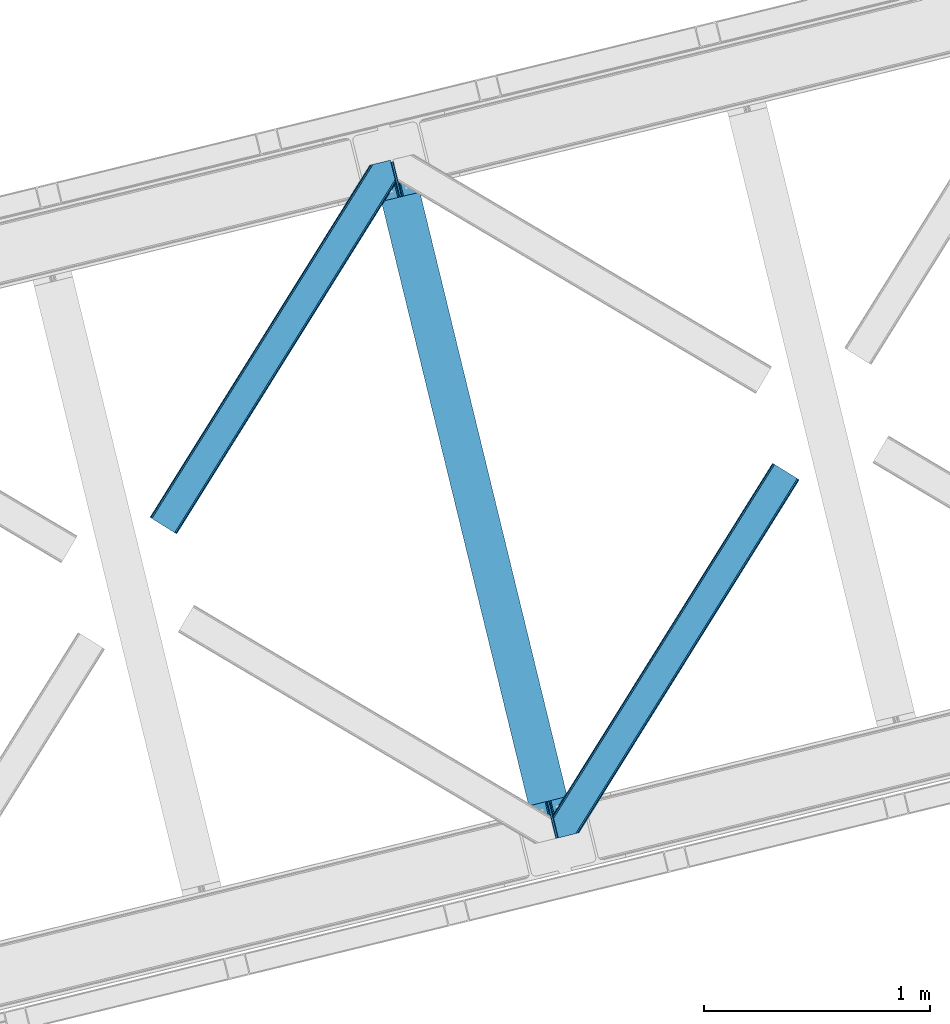
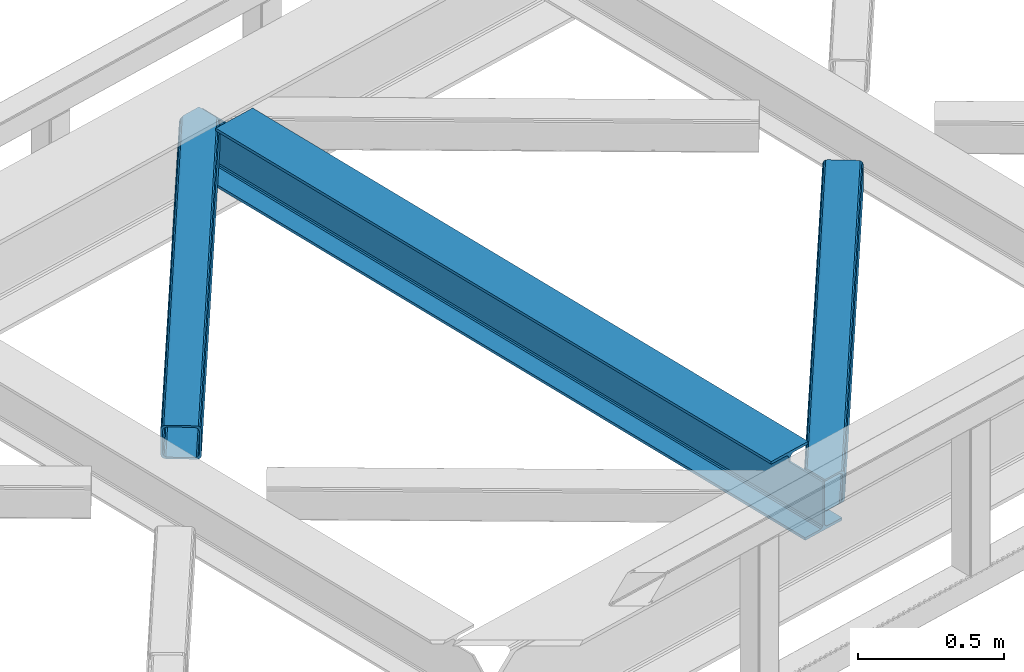
# One storey, part 59 of 93: 2 members, 1 beam.
"""IFC4 building model written with IfcOpenShell, lengths in millimetres."""

from ifc_helpers import new_model, entity, si_unit, converted_unit, derived_unit, direction, frame, origin, place, context, subcontext, project, spatial, triangles, polygons, material, type_object, element, save


model = new_model("IFC4")

# Units and contexts
model_context = context("Model", 3, precision=0.01, world=origin(), true_north=direction((6.12303176911189e-17, 1.0)))
plan_context = context("Plan", 3, precision=0.01, world=origin(), true_north=direction((6.12303176911189e-17, 1.0)))
body_context = subcontext(model_context, "Body", "Model", "MODEL_VIEW")
ifc_project = project(units=[si_unit("LENGTHUNIT", "METRE", prefix="MILLI"), si_unit("AREAUNIT", "SQUARE_METRE"), si_unit("VOLUMEUNIT", "CUBIC_METRE"), converted_unit("PLANEANGLEUNIT", "DEGREE", entity("IfcRatioMeasure", 0.0174532925199433), si_unit("PLANEANGLEUNIT", "RADIAN"), dimensions=[0, 0, 0, 0, 0, 0, 0]), si_unit("MASSUNIT", "GRAM", prefix="KILO"), derived_unit("MASSDENSITYUNIT", [(si_unit("MASSUNIT", "GRAM", prefix="KILO"), 1), (si_unit("LENGTHUNIT", "METRE"), -3)]), derived_unit("MOMENTOFINERTIAUNIT", [(si_unit("LENGTHUNIT", "METRE"), 4)]), si_unit("TIMEUNIT", "SECOND"), si_unit("FREQUENCYUNIT", "HERTZ"), si_unit("THERMODYNAMICTEMPERATUREUNIT", "DEGREE_CELSIUS"), derived_unit("THERMALTRANSMITTANCEUNIT", [(si_unit("MASSUNIT", "GRAM", prefix="KILO"), 1), (si_unit("THERMODYNAMICTEMPERATUREUNIT", "KELVIN"), -1), (si_unit("TIMEUNIT", "SECOND"), -3)]), derived_unit("VOLUMETRICFLOWRATEUNIT", [(si_unit("LENGTHUNIT", "METRE"), 3), (si_unit("TIMEUNIT", "SECOND"), -1)]), derived_unit("MASSFLOWRATEUNIT", [(si_unit("MASSUNIT", "GRAM", prefix="KILO"), 1), (si_unit("TIMEUNIT", "SECOND"), -1)]), derived_unit("ROTATIONALFREQUENCYUNIT", [(si_unit("TIMEUNIT", "SECOND"), -1)]), si_unit("ELECTRICCURRENTUNIT", "AMPERE"), si_unit("ELECTRICVOLTAGEUNIT", "VOLT"), si_unit("POWERUNIT", "WATT"), si_unit("FORCEUNIT", "NEWTON", prefix="KILO"), si_unit("ILLUMINANCEUNIT", "LUX"), si_unit("LUMINOUSFLUXUNIT", "LUMEN"), si_unit("LUMINOUSINTENSITYUNIT", "CANDELA"), derived_unit("USERDEFINED", [(si_unit("MASSUNIT", "GRAM", prefix="KILO"), -1), (si_unit("LENGTHUNIT", "METRE"), -2), (si_unit("TIMEUNIT", "SECOND"), 3), (si_unit("LUMINOUSFLUXUNIT", "LUMEN"), 1)]), derived_unit("LINEARVELOCITYUNIT", [(si_unit("LENGTHUNIT", "METRE"), 1), (si_unit("TIMEUNIT", "SECOND"), -1)]), si_unit("PRESSUREUNIT", "PASCAL"), derived_unit("USERDEFINED", [(si_unit("LENGTHUNIT", "METRE"), -2), (si_unit("MASSUNIT", "GRAM", prefix="KILO"), 1), (si_unit("TIMEUNIT", "SECOND"), -2)]), derived_unit("LINEARFORCEUNIT", [(si_unit("MASSUNIT", "GRAM", prefix="KILO"), 1), (si_unit("LENGTHUNIT", "METRE"), 1), (si_unit("TIMEUNIT", "SECOND"), -2), (si_unit("LENGTHUNIT", "METRE"), -1)]), derived_unit("PLANARFORCEUNIT", [(si_unit("MASSUNIT", "GRAM", prefix="KILO"), 1), (si_unit("LENGTHUNIT", "METRE"), 1), (si_unit("TIMEUNIT", "SECOND"), -2), (si_unit("LENGTHUNIT", "METRE"), -2)])], contexts=[model_context, plan_context])

# Site, building, storey
site_placement = place(None, origin())
site = spatial("IfcSite", under=ifc_project, at=site_placement, CompositionType="ELEMENT")
building_placement = place(site_placement, origin())
building = spatial("IfcBuilding", under=site, at=building_placement, CompositionType="ELEMENT")
storey_placement = place(building_placement, frame((0.0, 0.0, 15900.0)))
storey = spatial("IfcBuildingStorey", under=building, at=storey_placement, CompositionType="ELEMENT", Elevation=15900.0)

# Beam
ifc_material = material(Name="Metal painted (White)")
beam_type = type_object("IfcBeamType", PredefinedType="BEAM")
beam_placement = place(storey_placement, frame((-27174.2031424521, 11162.1857307485, 3441.0)))
element("IfcBeam", 1, at=beam_placement, inside=storey, type_object=beam_type, material=ifc_material, ObjectType="Steel Beam", PredefinedType="BEAM", context=body_context, shape_type="Tessellation", body=[
    polygons([(898.85391135252, 41.4445662733103, 11.000000000004), (898.85391135252, 41.4445662733103, 2.16573425859679e-12), (170.021610174761, 3031.3960252037, 2.16573425859679e-12), (170.021610174761, 3031.3960252037, 11.000000000004), (832.788371398898, 25.3403919499656, 11.000000000004), (103.956070221135, 3015.29185088035, 11.000000000004), (826.839621377606, 23.8903211957417, 12.2179274798217), (98.0073201998427, 3013.84178012613, 12.2179274798217), (821.796514621506, 22.6610105689216, 15.6862915010192), (92.9642134437384, 3012.61246949931, 15.6862915010192), (818.42681841833, 21.839611468714, 20.8770650821657), (89.5945172405625, 3011.7910703991, 20.8770650821657), (817.243538468644, 21.5511744621227, 27.0000000000047), (88.4112372908809, 3011.50263339251, 27.0000000000047), (81.6103728838888, 3009.84485074157, 27.0000000000047), (81.6103728838844, 3009.84485074157, 203.000000000006), (88.4112372908766, 3011.50263339251, 203.000000000006), (0.0, 2989.95145893039, 2.16573425859679e-12), (4.33146851719357e-12, 2989.95145893039, 10.9999999999997), (66.0655399536259, 3006.05563325373, 11.000000000004), (72.0142899749184, 3007.50570400796, 12.2179274798217), (77.0573967310183, 3008.73501463478, 15.6862915010192), (80.4270929342029, 3009.55641373498, 20.8770650821613), (817.243538468635, 21.5511744621206, 203.000000000006), (810.442674061647, 19.8933918111876, 203.000000000006), (810.442674061647, 19.8933918111876, 27.0000000000047), (809.259394111961, 19.6049548045963, 20.8770650821613), (805.889697908786, 18.7835557043887, 15.6862915010192), (800.846591152681, 17.5542450775685, 12.2179274798217), (794.897841131384, 16.1041743233425, 11.000000000004), (728.832301177763, 0.0, 10.9999999999997), (728.832301177763, 0.0, 2.16573425859679e-12), (777.543778045845, 184.415062601692, 203.069791966819), (125.888966506596, 2857.75452019162, 203.000000000006), (126.111847295746, 2856.84017775719, 203.617301946336), (126.12476154027, 2856.7871977843, 217.000003693143), (777.398574796916, 185.010597404072, 217.000003676718), (777.399445404814, 185.007025963192, 204.00000679514), (770.833476881403, 182.385463974445, 203.006342981529), (770.610629219866, 183.299815969774, 203.617301946336), (770.597714975338, 183.352795942669, 217.000003693143), (119.323901718691, 2855.1293963229, 217.000003676718), (119.323031110798, 2855.13296776378, 204.00000679514), (119.178731521743, 2855.72494066435, 203.076120467494), (119.088102099604, 2856.09673754069, 203.000000000006), (778.582059520952, 185.298194377514, 223.122939328039), (781.951055929623, 186.122464201393, 228.313710402595), (786.993691333646, 187.353708426697, 231.782072735464), (792.942270204354, 188.804481281379, 232.999999602236), (859.007721069873, 204.909021065315, 232.999999283132), (859.00624773344, 204.915065042188, 243.999994005812), (688.984866829523, 163.469558245298, 243.999994827032), (688.986340165961, 163.463514268424, 233.000000104353), (755.051791031484, 179.568054052358, 232.999999785253), (761.000696159814, 181.017488520584, 231.782072861012), (766.044260666937, 182.244921343716, 228.313710479427), (769.414647576681, 183.063487001148, 223.12293937232), (118.140416994656, 2854.84179934945, 223.122939328039), (114.771420585981, 2854.01752952557, 228.313710402595), (109.728785181961, 2852.78628530027, 231.782072735464), (103.780206311249, 2851.33551244559, 232.999999602236), (37.7147554457342, 2835.23097266165, 232.999999283128), (37.7162287821717, 2835.22492868478, 243.999994005812), (207.737609686088, 2876.67043548167, 243.999994827032), (207.736136349647, 2876.67647945854, 233.000000104357), (141.670685484123, 2860.57193967461, 232.999999785253), (135.721780355793, 2859.12250520639, 231.782072861012), (130.678215848667, 2857.89507238325, 228.313710479427), (127.307828938922, 2857.07650672582, 223.12293937232)], [[[1, 2, 3, 4]], [[5, 1, 4, 6]], [[7, 5, 6, 8]], [[9, 7, 8, 10]], [[11, 9, 10, 12]], [[13, 11, 12, 14]], [[15, 16, 17, 14, 12, 10, 8, 6, 4, 3, 18, 19, 20, 21, 22, 23]], [[13, 24, 25, 26, 27, 28, 29, 30, 31, 32, 2, 1, 5, 7, 9, 11]], [[2, 32, 18, 3]], [[32, 31, 19, 18]], [[31, 30, 20, 19]], [[27, 26, 15, 23]], [[28, 27, 23, 22]], [[29, 28, 22, 21]], [[30, 29, 21, 20]], [[33, 24, 13, 14, 17, 34, 35, 36, 37, 38]], [[25, 39, 40, 41, 42, 43, 44, 16, 15, 26]], [[39, 25, 24, 33]], [[45, 34, 17, 16]], [[41, 40, 38, 37, 46, 47, 48, 49, 50, 51, 52, 53, 54, 55, 56, 57]], [[42, 58, 59, 60, 61, 62, 63, 64, 65, 66, 67, 68, 69, 36, 35, 43]], [[46, 37, 36, 69]], [[47, 46, 69, 68]], [[48, 47, 68, 67]], [[49, 48, 67, 66]], [[50, 49, 66, 65]], [[51, 50, 65, 64]], [[52, 51, 64, 63]], [[53, 52, 63, 62]], [[54, 53, 62, 61]], [[55, 54, 61, 60]], [[56, 55, 60, 59]], [[57, 56, 59, 58]], [[41, 57, 58, 42]]], closed=False),
])

# Members
member_type_1 = type_object("IfcMemberType", PredefinedType="BRACE")
member_1_placement = place(storey_placement, frame((-28160.1625305176, 12527.4864990234, 3510.00011901855)))
element("IfcMember", 2, at=member_1_placement, inside=storey, type_object=member_type_1, ObjectType="Steel Horizontal Brace", PredefinedType="BRACE", context=body_context, shape_type="Tessellation", body=[
    triangles([(933.019793701173, 1535.69230957031, 0.0), (967.780462646486, 1393.09171142578, 0.0), (14.8479309082031, 64.8704589843746, 0.0), (103.9169128418, 9.2680389404286, 0.0), (928.803771972656, 1552.99125366211, 5.49966430664063), (928.943298339844, 1552.41687011719, 5.20782165527635), (930.803649902344, 1544.78710327148, 1.33247680664135), (971.998809814453, 1375.79276733398, 5.49966430664063), (971.856958007815, 1376.36715087891, 5.20782165527635), (969.998931884766, 1383.99691772461, 1.33247680664135), (972.210424804689, 1375.53813171387, 5.85313110351854), (972.424365234376, 1375.28349609375, 6.20659790039281), (928.915393066407, 1553.57028808594, 5.74383544921875), (972.726672363282, 1375.53813171387, 6.35310058594041), (929.029339599612, 1554.1772277832, 5.9996337890625), (973.026654052737, 1375.79276733398, 6.49960327148438), (929.145611572269, 1554.78416748047, 6.25659484863354), (929.254907226565, 1555.36203918457, 6.49960327148438), (4.34857177734375, 71.4223846435543, 5.12526855468968), (1.13248901367479, 73.4315643310547, 10.8028289794929), (973.361517333986, 1630.84347839355, 10.8028289794929), (976.917114257813, 1631.70970458984, 6.49960327148438), (9.16455688476708, 68.415591430663, 1.33247680664135), (971.508142089846, 1630.39118041992, 17.5000946044929), (0.0, 74.1373352050778, 17.5000946044929), (1081.10145263672, 1548.91708374023, 6.49960327148438), (1056.20762329102, 1651.03759460449, 6.49960327148438), (971.508142089846, 1630.39118041992, 122.500662231447), (0.0, 74.1373352050778, 122.500662231447), (973.361517333986, 1630.84347839355, 129.197927856447), (1.13248901367479, 73.4315643310547, 129.197927856447), (978.633288574219, 1632.12828369141, 134.874325561526), (4.34857177734375, 71.4223846435543, 134.874325561526), (986.530480957033, 1634.05374755859, 138.667117309571), (9.16455688476708, 68.415591430663, 138.667117309571), (995.841540527344, 1636.32221374512, 139.999594116212), (14.8479309082031, 64.8704589843746, 139.999594116212), (118.760192871094, 0.0, 17.5000946044929), (117.632354736328, 0.705770874023074, 10.8028289794929), (1085.14306640625, 1551.25066223144, 10.9783996582046), (1087.41734619141, 1552.56453552246, 13.5003387451179), (109.597961425781, 5.7205810546875, 1.33247680664135), (114.413946533205, 2.71495056152344, 5.12526855468968), (1087.57082519531, 1551.93550415039, 17.5000946044929), (1081.77815551758, 1575.70265808105, 139.999594116212), (1063.00953369141, 1652.69563293457, 139.999594116212), (103.9169128418, 9.2680389404286, 139.999594116212), (1083.99429931641, 1566.60670166016, 138.667117309571), (109.597961425781, 5.7205810546875, 138.667117309571), (1085.87325439453, 1558.89670715332, 134.874325561526), (114.413946533205, 2.71495056152344, 134.874325561526), (1087.12899169922, 1553.74469604492, 129.197927856447), (117.632354736328, 0.705770874023074, 129.197927856447), (1087.57082519531, 1551.93550415039, 122.500662231447), (118.760192871094, 0.0, 122.500662231447), (1082.53857421875, 1566.77413330078, 12.1260040283232), (1083.96639404297, 1566.72413635254, 13.5003387451179), (1077.8528137207, 1569.98556518555, 8.3320495605476), (1074.6483581543, 1577.50138549805, 6.99957275390625), (1056.69364013672, 1651.1561920166, 6.99957275390625), (1005.57350463867, 1638.69532470703, 6.99957275390625), (20.784777832032, 61.1625457763676, 6.99957275390625), (97.9777404785164, 12.9736267089847, 6.99957275390625), (108.474774169925, 6.42170104980505, 12.1260040283232), (111.693182373048, 4.41252136230469, 17.8035644531265), (1084.81285400391, 1563.2510925293, 17.8035644531265), (103.661114501956, 9.42849426269458, 8.3320495605476), (1085.25236206055, 1561.44190063477, 24.4996673583992), (112.823345947269, 3.70791320800708, 24.4996673583992), (983.093481445314, 1633.21542663574, 17.8035644531265), (981.240106201174, 1632.76429138184, 24.4996673583992), (7.0693359375, 69.7248138427731, 17.8035644531265), (5.94149780273438, 70.4305847167961, 24.4996673583992), (988.369903564453, 1634.50139465332, 12.1260040283232), (10.2877441406272, 67.7156341552727, 12.1260040283232), (996.262445068362, 1636.42569580078, 8.3320495605476), (15.1037292480469, 64.7100036621086, 8.3320495605476), (981.240106201174, 1632.76429138184, 115.501089477541), (5.94149780273438, 70.4305847167961, 115.501089477541), (996.262445068362, 1636.42569580078, 131.667544555665), (1005.57350463867, 1638.69532470703, 133.000021362306), (1063.00953369141, 1652.69563293457, 133.000021362306), (988.369903564453, 1634.50139465332, 127.87475280762), (983.093481445314, 1633.21542663574, 122.196029663086), (20.784777832032, 61.1625457763676, 133.000021362306), (15.1037292480469, 64.7100036621086, 131.667544555665), (10.2877441406272, 67.7156341552727, 127.87475280762), (7.0693359375, 69.7248138427731, 122.196029663086), (108.474774169925, 6.42170104980505, 127.87475280762), (111.693182373048, 4.41252136230469, 122.196029663086), (112.823345947269, 3.70791320800708, 115.501089477541), (97.9777404785164, 12.9736267089847, 133.000021362306), (103.661114501956, 9.42849426269458, 131.667544555665), (1085.25236206055, 1561.44190063477, 115.501089477541), (1084.81285400391, 1563.2510925293, 122.196029663086), (1083.55711669922, 1568.40310363769, 127.87475280762), (1081.67583618164, 1576.11309814453, 131.667544555665), (1079.45969238281, 1585.20905456543, 133.000021362306)], [[1, 2, 3], [4, 3, 2], [1, 5, 2], [6, 5, 1], [1, 7, 6], [2, 5, 8], [8, 9, 2], [10, 2, 9], [11, 8, 5], [12, 11, 13], [14, 12, 15], [16, 14, 17], [17, 18, 16], [15, 17, 14], [13, 15, 12], [5, 13, 11], [17, 19, 18], [19, 17, 15], [13, 19, 15], [19, 13, 5], [5, 6, 19], [20, 21, 18], [18, 19, 20], [21, 22, 18], [19, 6, 7], [7, 1, 23], [3, 23, 1], [7, 23, 19], [24, 21, 20], [20, 25, 24], [18, 26, 16], [26, 18, 22], [27, 26, 22], [28, 24, 29], [25, 29, 24], [30, 28, 31], [29, 31, 28], [32, 30, 33], [31, 33, 30], [34, 32, 35], [33, 35, 32], [36, 34, 37], [35, 37, 34], [38, 39, 40], [40, 41, 38], [42, 10, 9], [39, 12, 16], [16, 40, 39], [16, 26, 40], [9, 39, 43], [9, 12, 39], [9, 43, 42], [2, 10, 4], [42, 4, 10], [41, 44, 38], [45, 36, 37], [36, 45, 46], [37, 47, 45], [48, 45, 47], [47, 49, 48], [50, 48, 49], [49, 51, 50], [52, 50, 51], [51, 53, 52], [54, 52, 53], [53, 55, 54], [44, 54, 38], [55, 38, 54], [56, 40, 26], [41, 40, 56], [56, 57, 41], [58, 26, 59], [26, 58, 56], [60, 59, 26], [59, 61, 62], [61, 59, 60], [62, 63, 59], [64, 65, 66], [66, 57, 64], [58, 59, 63], [63, 67, 58], [56, 58, 67], [67, 64, 56], [57, 56, 64], [68, 66, 65], [65, 69, 68], [70, 71, 72], [73, 72, 71], [74, 70, 75], [72, 75, 70], [76, 74, 77], [75, 77, 74], [61, 76, 62], [77, 62, 76], [71, 78, 73], [79, 73, 78], [34, 36, 80], [46, 81, 36], [81, 46, 82], [81, 80, 36], [83, 34, 80], [83, 32, 34], [32, 84, 30], [84, 32, 83], [28, 84, 78], [84, 28, 30], [61, 22, 76], [70, 74, 22], [74, 76, 22], [61, 60, 22], [71, 70, 24], [21, 24, 70], [28, 71, 24], [71, 28, 78], [70, 22, 21], [80, 81, 85], [85, 86, 80], [83, 80, 86], [86, 87, 83], [84, 83, 87], [87, 88, 84], [78, 84, 88], [88, 79, 78], [53, 89, 90], [91, 38, 55], [53, 90, 55], [53, 51, 89], [90, 91, 55], [89, 51, 49], [92, 47, 37], [47, 93, 49], [93, 47, 92], [93, 89, 49], [39, 64, 43], [69, 38, 91], [38, 65, 39], [65, 38, 69], [39, 65, 64], [4, 63, 3], [42, 43, 64], [64, 67, 42], [67, 63, 4], [4, 42, 67], [87, 35, 33], [37, 85, 92], [37, 86, 85], [86, 37, 35], [87, 86, 35], [79, 29, 25], [31, 88, 87], [33, 31, 87], [88, 31, 29], [79, 88, 29], [23, 75, 19], [3, 63, 62], [62, 77, 3], [77, 75, 23], [23, 3, 77], [20, 19, 75], [25, 73, 79], [72, 25, 20], [25, 72, 73], [72, 20, 75], [66, 41, 57], [54, 44, 68], [44, 66, 68], [68, 94, 54], [44, 41, 66], [95, 54, 94], [52, 54, 95], [50, 95, 96], [95, 50, 52], [96, 48, 50], [97, 48, 96], [97, 98, 45], [97, 45, 48], [98, 46, 45], [98, 82, 46], [81, 98, 85], [81, 82, 98], [92, 85, 98], [95, 94, 90], [91, 90, 94], [96, 95, 89], [90, 89, 95], [97, 96, 93], [89, 93, 96], [98, 97, 92], [93, 92, 97], [94, 68, 91], [69, 91, 68]]),
])
member_type_2 = type_object("IfcMemberType", PredefinedType="BRACE")
member_2_placement = place(storey_placement, frame((-26379.092175293, 11184.3289489746, 3510.00011901855)))
element("IfcMember", 3, at=member_2_placement, inside=storey, type_object=member_type_2, ObjectType="Steel Horizontal Brace", PredefinedType="BRACE", context=body_context, shape_type="Tessellation", body=[
    triangles([(986.153759765624, 1647.42967529297, 0.0), (1075.22274169922, 1591.82725524902, 0.0), (119.788037109374, 259.603921508789, 0.0), (154.548706054688, 117.003323364259, 0.0), (115.902227783201, 275.544808959961, 4.52065429687718), (117.571893310545, 268.698715209961, 1.33247680664135), (158.434515380857, 101.062435913087, 4.52065429687718), (156.764849853513, 107.908529663086, 1.33247680664135), (114.825549316403, 275.742471313477, 5.52059326172093), (115.130181884764, 275.923855590821, 5.35316162109666), (158.132208251951, 99.1218566894531, 5.27525939941552), (115.439465332031, 276.107565307617, 5.18107910156323), (158.232202148436, 99.7776306152355, 5.02062377929906), (158.188018798828, 99.4822998046875, 5.13573303222802), (115.541784667967, 276.1680267334, 5.12526855468968), (115.683636474609, 275.921530151367, 4.88574829101708), (158.336846923827, 100.433404541016, 4.76482543945531), (158.032214355466, 98.4928253173839, 5.52059326172093), (1085.71977539062, 1585.27416687012, 5.12526855468968), (1080.90146484375, 1588.28096008301, 1.33247680664135), (1088.93818359375, 1583.26498718262, 10.8028289794929), (114.21163330078, 21.8533172607422, 10.8028289794929), (109.467736816405, 20.6964111328125, 5.52059326172093), (1090.06602172851, 1582.56037902832, 17.5000946044929), (116.062683105469, 22.3044525146488, 17.5000946044929), (6.75307617187354, 102.619317626953, 5.52059326172093), (31.3632019042961, 1.65803833007885, 5.52059326172093), (1090.06602172851, 1582.56037902832, 122.500662231447), (116.062683105469, 22.3044525146488, 122.500662231447), (1088.93818359375, 1583.26498718262, 129.197927856447), (114.21163330078, 21.8533172607422, 129.197927856447), (1085.71977539062, 1585.27416687012, 134.874325561526), (108.935211181641, 20.5673492431652, 134.874325561526), (1080.90146484375, 1588.28096008301, 138.667117309571), (101.042669677732, 18.6430480957042, 138.667117309571), (1075.22274169922, 1591.82725524902, 139.999594116212), (91.7292846679666, 16.3722564697273, 139.999594116212), (980.472711181639, 1650.97597045899, 1.33247680664135), (975.656726074216, 1653.98276367187, 5.12526855468968), (1.69059448242115, 100.411312866212, 10.9621215820334), (972.438317871092, 1655.99078063965, 10.8028289794929), (971.308154296872, 1656.69655151367, 17.5000946044929), (0.239520263668965, 99.7776306152355, 12.5201660156272), (0.0, 100.760128784181, 17.5000946044929), (5.79266967773219, 76.9941375732433, 139.999594116212), (986.153759765624, 1647.42967529297, 139.999594116212), (24.5612915039055, 0.0, 139.999594116212), (971.308154296872, 1656.69655151367, 122.500662231447), (0.0, 100.760128784181, 122.500662231447), (980.472711181639, 1650.97597045899, 138.667117309571), (3.57652587890334, 86.0889312744148, 138.667117309571), (975.656726074216, 1653.98276367187, 134.874325561526), (1.69524536132667, 93.7989257812496, 134.874325561526), (972.438317871092, 1655.99078063965, 129.197927856447), (0.43950805663917, 98.9509368896488, 129.197927856447), (29.9237548828096, 1.30689697265734, 6.99957275390625), (12.1969299316406, 74.0326904296871, 6.99957275390625), (8.99247436523365, 81.5485107421882, 8.3320495605476), (3.88580932616969, 84.8122650146488, 12.5201660156272), (1069.28589477539, 1595.53400573731, 6.99957275390625), (81.9949951171875, 14.0003082275398, 6.99957275390625), (992.090606689453, 1643.72292480469, 6.99957275390625), (981.593572998045, 1650.27601318359, 12.1260040283232), (978.375164794921, 1652.28403015137, 17.8035644531265), (2.75797119140407, 89.4445404052731, 17.8035644531265), (986.409558105468, 1647.2692199707, 8.3320495605476), (977.245001220701, 1652.98980102539, 24.4996673583992), (2.31613769531032, 91.2537322998051, 24.4996673583992), (977.245001220701, 1652.98980102539, 115.501089477541), (2.31613769531032, 91.2537322998051, 115.501089477541), (4.01370849609157, 84.2925292968757, 127.87475280762), (2.75797119140407, 89.4445404052731, 122.196029663086), (5.89266357421729, 76.5825347900391, 131.667544555665), (8.10880737304615, 67.4865783691403, 133.000021362306), (24.5612915039055, 0.0, 133.000021362306), (978.375164794921, 1652.28403015137, 122.196029663086), (981.593572998045, 1650.27601318359, 127.87475280762), (986.409558105468, 1647.2692199707, 131.667544555665), (992.090606689453, 1643.72292480469, 133.000021362306), (1069.28589477539, 1595.53400573731, 133.000021362306), (81.9949951171875, 14.0003082275398, 133.000021362306), (1079.78060302734, 1588.9809173584, 12.1260040283232), (1082.99901123047, 1586.97290039063, 17.8035644531265), (1084.12917480469, 1586.2671295166, 24.4996673583992), (1074.96461791992, 1591.98771057129, 8.3320495605476), (1079.78060302734, 1588.9809173584, 127.87475280762), (1084.12917480469, 1586.2671295166, 115.501089477541), (1082.99901123047, 1586.97290039063, 122.196029663086), (1074.96461791992, 1591.98771057129, 131.667544555665), (91.3083801269531, 16.2699371337894, 131.667544555665), (99.2032470703125, 18.1942382812504, 127.87475280762), (104.477343749997, 19.4802062988292, 122.196029663086), (106.330718994141, 19.9325042724613, 115.501089477541), (91.3083801269531, 16.2699371337894, 8.3320495605476), (104.477343749997, 19.4802062988292, 17.8035644531265), (99.2032470703125, 18.1942382812504, 12.1260040283232), (106.330718994141, 19.9325042724613, 24.4996673583992)], [[1, 2, 3], [4, 3, 2], [5, 3, 4], [3, 5, 6], [4, 7, 5], [7, 4, 8], [9, 10, 11], [10, 12, 13], [13, 14, 10], [12, 15, 16], [16, 17, 12], [16, 5, 7], [7, 17, 16], [17, 13, 12], [14, 11, 10], [11, 18, 9], [19, 14, 13], [13, 20, 19], [13, 17, 20], [17, 7, 20], [7, 8, 20], [21, 22, 18], [18, 19, 21], [14, 19, 11], [18, 11, 19], [22, 23, 18], [21, 24, 25], [25, 22, 21], [2, 20, 4], [8, 4, 20], [23, 26, 18], [23, 27, 26], [9, 18, 26], [24, 28, 29], [29, 25, 24], [28, 30, 29], [31, 29, 30], [30, 32, 31], [33, 31, 32], [32, 34, 33], [35, 33, 34], [34, 36, 35], [37, 35, 36], [38, 6, 5], [5, 39, 38], [5, 15, 39], [40, 41, 9], [41, 39, 15], [42, 41, 40], [40, 43, 42], [43, 44, 42], [9, 26, 40], [38, 1, 6], [3, 6, 1], [36, 45, 37], [36, 46, 45], [45, 47, 37], [48, 42, 44], [44, 49, 48], [46, 50, 51], [51, 45, 46], [50, 52, 53], [53, 51, 50], [52, 54, 55], [55, 53, 52], [54, 48, 49], [49, 55, 54], [27, 56, 57], [26, 57, 58], [57, 26, 27], [59, 40, 26], [26, 58, 59], [43, 40, 59], [60, 57, 61], [60, 62, 57], [57, 56, 61], [63, 64, 65], [65, 59, 63], [66, 63, 59], [62, 66, 58], [58, 57, 62], [59, 58, 66], [64, 67, 68], [68, 65, 64], [67, 69, 70], [70, 68, 67], [71, 53, 72], [73, 74, 45], [74, 47, 45], [74, 75, 47], [51, 73, 45], [71, 51, 53], [71, 73, 51], [49, 68, 70], [55, 72, 53], [70, 72, 49], [72, 55, 49], [44, 68, 49], [43, 59, 65], [65, 68, 44], [44, 43, 65], [69, 76, 70], [72, 70, 76], [76, 77, 72], [71, 72, 77], [77, 78, 71], [73, 71, 78], [78, 79, 73], [74, 73, 79], [80, 74, 79], [74, 80, 81], [75, 74, 81], [21, 82, 83], [84, 28, 24], [21, 83, 24], [21, 19, 82], [83, 84, 24], [82, 19, 20], [60, 2, 1], [2, 85, 20], [85, 2, 60], [85, 82, 20], [30, 86, 32], [87, 28, 84], [28, 88, 30], [88, 28, 87], [30, 88, 86], [36, 80, 46], [34, 32, 86], [86, 89, 34], [89, 80, 36], [36, 34, 89], [63, 38, 39], [1, 62, 60], [1, 66, 62], [66, 1, 38], [63, 66, 38], [67, 42, 48], [41, 64, 63], [39, 41, 63], [64, 41, 42], [67, 64, 42], [50, 77, 52], [46, 80, 79], [79, 78, 46], [78, 77, 50], [50, 46, 78], [54, 52, 77], [48, 69, 67], [76, 48, 54], [48, 76, 69], [76, 54, 77], [35, 37, 90], [47, 81, 37], [81, 47, 75], [81, 90, 37], [91, 35, 90], [91, 33, 35], [33, 92, 31], [92, 33, 91], [29, 92, 93], [92, 29, 31], [61, 23, 94], [95, 96, 23], [96, 94, 23], [61, 27, 23], [27, 61, 56], [97, 95, 25], [22, 25, 95], [29, 97, 25], [97, 29, 93], [95, 23, 22], [80, 89, 90], [90, 81, 80], [89, 86, 91], [91, 90, 89], [86, 88, 92], [92, 91, 86], [88, 87, 93], [93, 92, 88], [87, 84, 97], [97, 93, 87], [84, 83, 97], [95, 97, 83], [83, 82, 95], [96, 95, 82], [82, 85, 96], [94, 96, 85], [85, 60, 94], [61, 94, 60]]),
])

save(model, "model.ifc")
